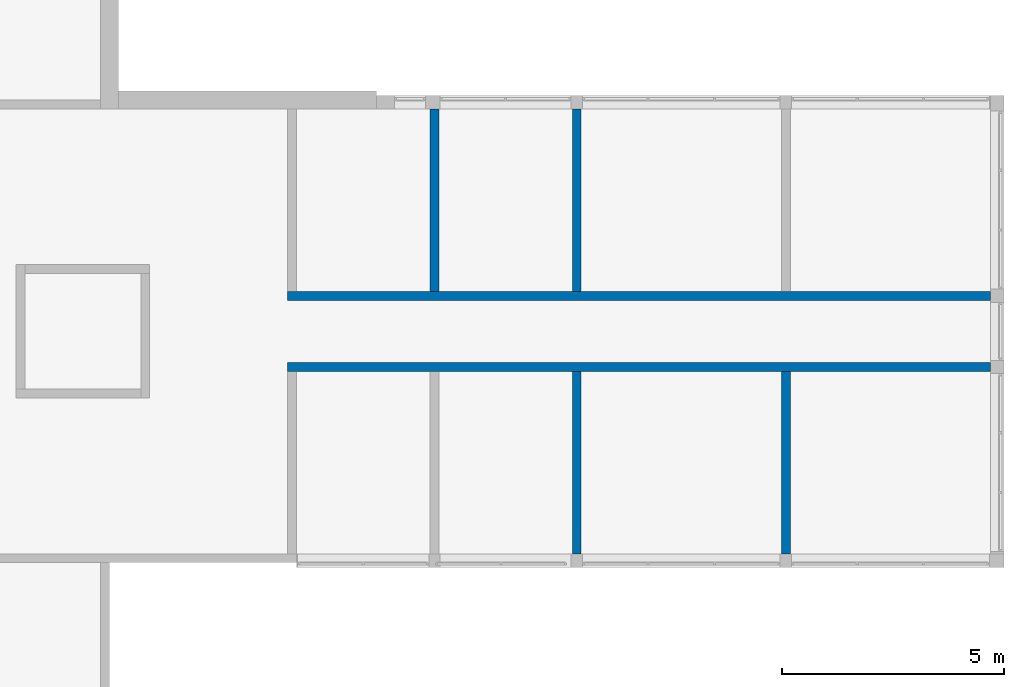
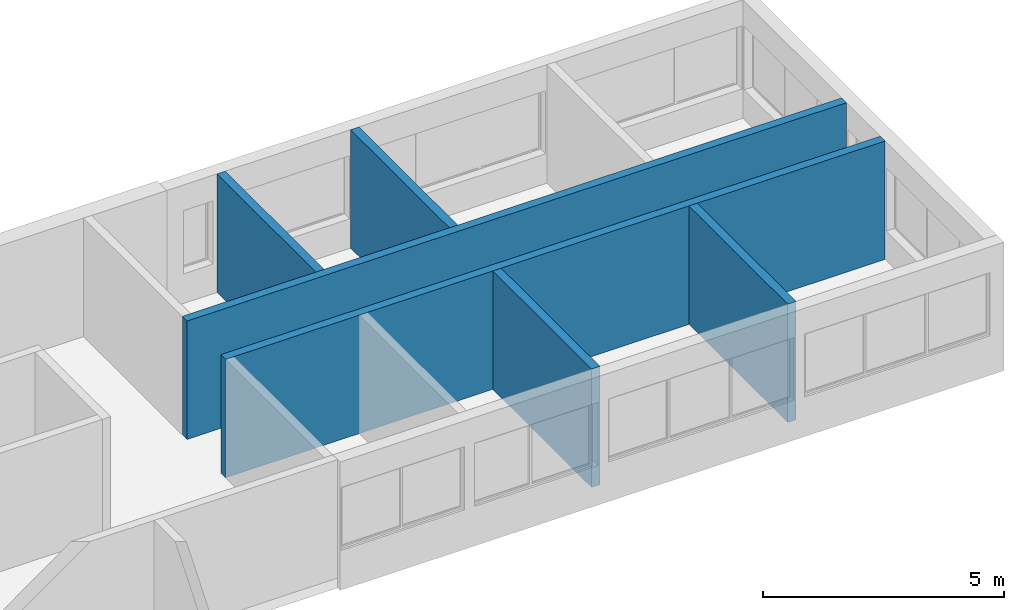
# One storey, part 7 of 16: 6 walls.
"""IFC4 building model written with IfcOpenShell, lengths in metres."""

from ifc_helpers import new_model, entity, si_unit, converted_unit, frame, origin_with_axes, origin_2d_with_axis, place, context, subcontext, project, spatial, indexed_curve, outline, extrude, material, layer, layer_set, layer_usage, type_object, element, save


model = new_model("IFC4")

# Units and contexts
model_context = context("Model", 3, precision=1e-05, world=origin_with_axes())
plan_context = context("Plan", 2, precision=1e-05, world=origin_2d_with_axis())
body_context = subcontext(model_context, "Body", "Model", "MODEL_VIEW")
ifc_project = project(units=[converted_unit("PLANEANGLEUNIT", "degree", entity("IfcReal", 0.0174532925199433), si_unit("PLANEANGLEUNIT", "RADIAN"), dimensions=[0, 0, 0, 0, 0, 0, 0]), si_unit("AREAUNIT", "SQUARE_METRE"), si_unit("VOLUMEUNIT", "CUBIC_METRE"), si_unit("LENGTHUNIT", "METRE")], contexts=[model_context, plan_context])

# Site, building, storey
site_placement = place(None, origin_with_axes())
site = spatial("IfcSite", under=ifc_project, at=site_placement)
building_placement = place(site_placement, origin_with_axes())
building = spatial("IfcBuilding", under=site, at=building_placement)
storey_placement = place(building_placement, frame((0.0, 0.0, 4.0), z_axis=(0.0, 0.0, 1.0), x_axis=(1.0, 0.0, 0.0)))
storey = spatial("IfcBuildingStorey", under=building, at=storey_placement, Name="1.OG")

# Walls
ifc_material_1 = material(Name="Concrete_1.2_MA")
ifc_layer_1 = layer(ifc_material_1, 0.200000002980232, Name="Concrete")
ifc_layer_set_1 = layer_set([ifc_layer_1], Name="Wall_IW")
ifc_layer_usage_1 = layer_usage(ifc_layer_set_1, "AXIS2", "POSITIVE", 0.0)
wall_type_1 = type_object("IfcWallType", Name="IW", PredefinedType="NOTDEFINED", material=ifc_layer_set_1)
wall_1_placement = place(storey_placement, frame((34.2130279541016, -14.9051847457886, 0.25), z_axis=(0.0, 0.0, 1.0), x_axis=(-0.999999999999924, 3.89414367418765e-07, 0.0)))
element("IfcWall", 1, at=wall_1_placement, inside=storey, type_object=wall_type_1, material=ifc_layer_usage_1, Name="Wall", context=body_context, shape_type="SweptSolid", body=[
    extrude(outline(indexed_curve([(0.0, 0.0), (0.0, 0.200000002980232), (15.7999917718418, 0.200000002980232), (15.7999917718418, 0.0), (0.0, 0.0)], self_intersect=False)), origin_with_axes(), (0.0, 0.0, 1.0), 3.0),
])
ifc_layer_usage_2 = layer_usage(ifc_layer_set_1, "AXIS2", "POSITIVE", 0.0)
wall_2_placement = place(storey_placement, frame((34.2130317687988, -13.3051815032959, 0.25), z_axis=(0.0, 0.0, 1.0), x_axis=(-0.999999999999924, 3.89414367418765e-07, 0.0)))
element("IfcWall", 2, at=wall_2_placement, inside=storey, type_object=wall_type_1, material=ifc_layer_usage_2, Name="Wall", context=body_context, shape_type="SweptSolid", body=[
    extrude(outline(indexed_curve([(0.0, 0.0), (0.0, 0.200000002980232), (15.7999956348279, 0.200000002980232), (15.7999956348279, 0.0), (0.0, 0.0)], self_intersect=False)), origin_with_axes(), (0.0, 0.0, 1.0), 3.0),
])
ifc_material_2 = material(Name="Brick_0.5_MA")
ifc_layer_2 = layer(ifc_material_2, 0.200000002980232, Name="Brick")
ifc_layer_set_2 = layer_set([ifc_layer_2], Name="Wall_IW")
ifc_layer_usage_3 = layer_usage(ifc_layer_set_2, "AXIS2", "POSITIVE", 0.0)
wall_type_2 = type_object("IfcWallType", Name="IW", PredefinedType="NOTDEFINED", material=ifc_layer_set_2)
wall_3_placement = place(storey_placement, frame((25.0130348205566, -19.2051773071289, 0.25), z_axis=(0.0, 0.0, 1.0), x_axis=(3.13916473260163e-07, 0.999999999999951, 0.0)))
element("IfcWall", 3, at=wall_3_placement, inside=storey, type_object=wall_type_2, material=ifc_layer_usage_3, Name="Wall", context=body_context, shape_type="SweptSolid", body=[
    extrude(outline(indexed_curve([(0.0, 0.0), (0.0, 0.200000002980232), (4.09999853924981, 0.200000002980232), (4.09999853924981, 0.0), (0.0, 0.0)], self_intersect=False)), origin_with_axes(), (0.0, 0.0, 1.0), 3.0),
])
ifc_layer_usage_4 = layer_usage(ifc_layer_set_2, "AXIS2", "POSITIVE", 0.0)
wall_4_placement = place(storey_placement, frame((29.7130355834961, -19.2051773071289, 0.25), z_axis=(0.0, 0.0, 1.0), x_axis=(3.13916473260163e-07, 0.999999999999951, 0.0)))
element("IfcWall", 4, at=wall_4_placement, inside=storey, type_object=wall_type_2, material=ifc_layer_usage_4, Name="Wall", context=body_context, shape_type="SweptSolid", body=[
    extrude(outline(indexed_curve([(0.0, 0.0), (0.0, 0.200000002980232), (4.09999853924981, 0.200000002980232), (4.09999853924981, 0.0), (0.0, 0.0)], self_intersect=False)), origin_with_axes(), (0.0, 0.0, 1.0), 3.0),
])
ifc_layer_usage_5 = layer_usage(ifc_layer_set_2, "AXIS2", "POSITIVE", 0.0)
wall_5_placement = place(storey_placement, frame((21.8130340576172, -13.3051786422729, 0.25), z_axis=(0.0, 0.0, 1.0), x_axis=(3.13916473260163e-07, 0.999999999999951, 0.0)))
element("IfcWall", 5, at=wall_5_placement, inside=storey, type_object=wall_type_2, material=ifc_layer_usage_5, Name="Wall", context=body_context, shape_type="SweptSolid", body=[
    extrude(outline(indexed_curve([(0.0, 0.0), (0.0, 0.200000002980232), (4.09999853924981, 0.200000002980232), (4.09999853924981, 0.0), (0.0, 0.0)], self_intersect=False)), origin_with_axes(), (0.0, 0.0, 1.0), 3.0),
])
ifc_layer_usage_6 = layer_usage(ifc_layer_set_2, "AXIS2", "POSITIVE", 0.0)
wall_6_placement = place(storey_placement, frame((25.0130348205566, -13.3051786422729, 0.25), z_axis=(0.0, 0.0, 1.0), x_axis=(3.13916473260163e-07, 0.999999999999951, 0.0)))
element("IfcWall", 6, at=wall_6_placement, inside=storey, type_object=wall_type_2, material=ifc_layer_usage_6, Name="Wall", context=body_context, shape_type="SweptSolid", body=[
    extrude(outline(indexed_curve([(0.0, 0.0), (0.0, 0.200000002980232), (4.09999853924981, 0.200000002980232), (4.09999853924981, 0.0), (0.0, 0.0)], self_intersect=False)), origin_with_axes(), (0.0, 0.0, 1.0), 3.0),
])

save(model, "model.ifc")
